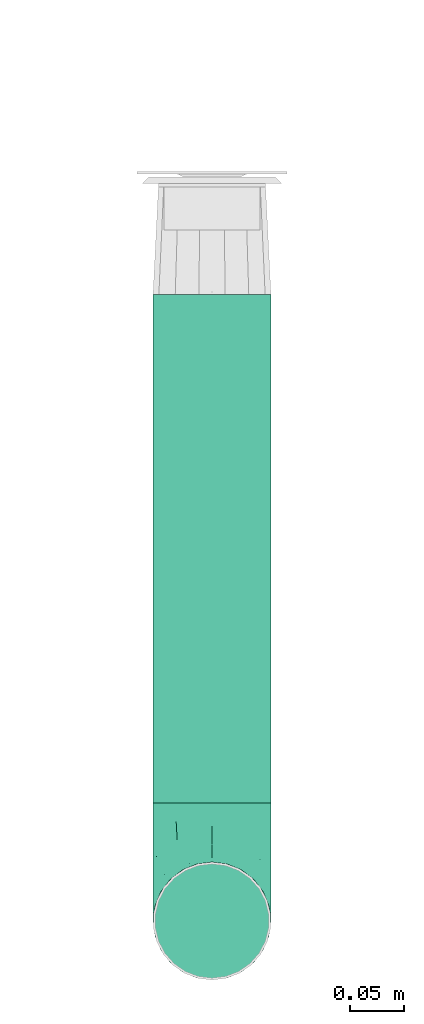
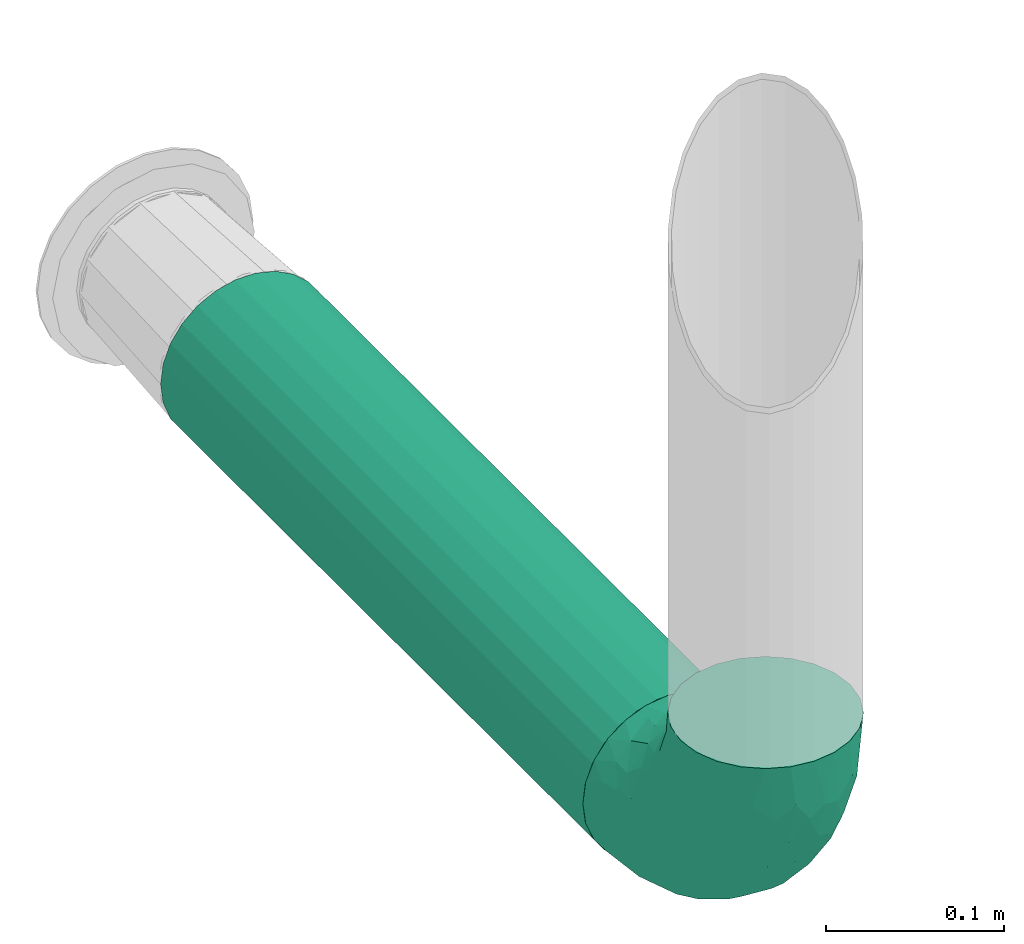
# One storey, part 13 of 115: 1 flow fitting, 1 flow segment.
"""IFC2X3 building model written with IfcOpenShell, lengths in millimetres."""

from ifc_helpers import new_model, entity, si_unit, converted_unit, derived_unit, direction, frame, origin_with_axes, origin_2d_with_axis, place, context, subcontext, project, spatial, hollow_circle, extrude, open_shell, surface_model, source, transform, mapped, material, layer, layer_set, layer_usage, type_object, element, save


model = new_model("IFC2X3")

# Units and contexts
model_context = context("Model", 3, precision=1e-05, world=origin_with_axes(), true_north=direction((0.0, 1.0)))
body_context = subcontext(model_context, "Body", "Model", "MODEL_VIEW")
ifc_project = project(units=[si_unit("AREAUNIT", "SQUARE_METRE"), si_unit("VOLUMEUNIT", "CUBIC_METRE", prefix="DECI"), si_unit("TIMEUNIT", "SECOND"), si_unit("THERMODYNAMICTEMPERATUREUNIT", "DEGREE_CELSIUS"), si_unit("PRESSUREUNIT", "PASCAL"), si_unit("MASSUNIT", "GRAM", prefix="KILO"), si_unit("LENGTHUNIT", "METRE", prefix="MILLI"), si_unit("POWERUNIT", "WATT"), si_unit("ELECTRICCURRENTUNIT", "AMPERE"), si_unit("ELECTRICVOLTAGEUNIT", "VOLT"), derived_unit("VOLUMETRICFLOWRATEUNIT", [(si_unit("VOLUMEUNIT", "CUBIC_METRE", prefix="DECI"), 1), (si_unit("TIMEUNIT", "SECOND"), -1)]), derived_unit("LINEARVELOCITYUNIT", [(si_unit("LENGTHUNIT", "METRE"), 1), (si_unit("TIMEUNIT", "SECOND"), -1)]), derived_unit("MASSDENSITYUNIT", [(si_unit("MASSUNIT", "GRAM", prefix="KILO"), 1), (si_unit("VOLUMEUNIT", "CUBIC_METRE"), -1)]), converted_unit("PLANEANGLEUNIT", "DEGREE", entity("IfcRatioMeasure", 0.01745), si_unit("PLANEANGLEUNIT", "RADIAN"), dimensions=[0, 0, 0, 0, 0, 0, 0])], contexts=[model_context])

# Site, building, storey
site_placement = place(None, origin_with_axes())
site = spatial("IfcSite", under=ifc_project, at=site_placement, CompositionType="ELEMENT")
building_placement = place(site_placement, origin_with_axes())
building = spatial("IfcBuilding", under=site, at=building_placement, Name="mc-building", CompositionType="ELEMENT")
storey_placement = place(building_placement, frame((0.0, 0.0, 2950.0), z_axis=(0.0, 0.0, 1.0), x_axis=(1.0, 0.0, 0.0)))
storey = spatial("IfcBuildingStorey", under=building, at=storey_placement, Name="2. Korrus", CompositionType="ELEMENT", Elevation=2950.0)

# Flow fitting
duct_fitting_type = type_object("IfcDuctFittingType", Name="BU", PredefinedType="BEND")
shared_shape_1 = source(origin_with_axes(), body_context, "Body", "SurfaceModel", [
    surface_model("IfcShellBasedSurfaceModel", [(-110.0, 0.0, -55.0), (-110.0, -14.23505, -53.12592), (-110.0, 14.23505, -53.12592), (-110.0, 53.12592, 14.23505), (-110.0, 27.5, -47.63139), (-110.0, 38.89087, -38.89087), (-110.0, -55.0, 0.0), (-110.0, -53.12592, 14.23505), (-110.0, -38.89087, -38.89087), (-110.0, -27.5, -47.63139), (-110.0, -53.12592, -14.23505), (-110.0, -47.63139, -27.5), (-110.0, -14.23505, 53.12592), (-110.0, 14.23505, 53.12592), (-110.0, 27.5, 47.63139), (-110.0, -47.63139, 27.5), (-110.0, -38.89087, 38.89087), (-110.0, -27.5, 47.63139), (-110.0, 0.0, 55.0), (-110.0, 55.0, 0.0), (-110.0, 53.12592, -14.23505), (-110.0, 47.63139, -27.5), (-110.0, 47.63139, 27.5), (-110.0, 38.89087, 38.89087), (-14.23505, 110.0, -53.12592), (-55.0, 110.0, 0.0), (0.0, 110.0, -55.0), (-27.5, 110.0, -47.63139), (-38.89087, 110.0, -38.89087), (-47.63139, 110.0, -27.5), (38.89087, 110.0, -38.89087), (53.12592, 110.0, 14.23505), (27.5, 110.0, -47.63139), (14.23505, 110.0, -53.12592), (47.63139, 110.0, -27.5), (53.12592, 110.0, -14.23505), (55.0, 110.0, 0.0), (-53.12592, 110.0, -14.23505), (-53.12592, 110.0, 14.23505), (-47.63139, 110.0, 27.5), (-38.89087, 110.0, 38.89087), (-27.5, 110.0, 47.63139), (0.0, 110.0, 55.0), (-14.23505, 110.0, 53.12592), (38.89087, 110.0, 38.89087), (47.63139, 110.0, 27.5), (27.5, 110.0, 47.63139), (14.23505, 110.0, 53.12592), (-64.21732, 48.68956, 43.63444), (-76.6405, 38.18013, 45.55988), (-60.44912, 32.56953, 51.94617), (-76.00813, 5.38378, 55.0), (-90.15553, 11.94394, 54.09138), (-78.5998, 26.77405, 50.81338), (-70.18771, 18.55163, 54.03432), (-75.55424, 54.2118, 32.41257), (-93.27622, 45.77614, 33.48188), (-96.12334, 22.13664, 50.81337), (-21.00813, 45.34362, 55.0), (-18.36258, 70.48427, 54.04484), (-32.04182, 59.64019, 52.24446), (-63.88653, 74.77858, 17.99134), (-74.66383, 63.08407, 19.92123), (-63.60674, 66.07878, 29.97482), (-99.597, 52.72185, 18.52927), (-93.11138, 56.59448, 10.50359), (-98.21577, 57.34403, 0.0), (-53.42855, 92.60092, 21.04759), (-88.54852, 54.8376, 21.04759), (-11.86161, 90.23965, 54.10313), (-5.38378, 76.00813, 55.0), (-57.34403, 98.21577, 0.0), (-56.64619, 93.12774, 10.22088), (-45.34362, 21.00813, 55.0), (-44.60838, 44.60838, 52.13415), (-92.68484, 35.46673, 43.63443), (-22.25266, 95.40765, 50.81337), (-35.97783, 90.61597, 43.63443), (-43.70931, 69.58671, 44.47149), (-27.23711, 77.39884, 50.81337), (-57.2828, 79.3123, 24.9774), (-58.67786, 84.31125, 16.04456), (-82.93277, 60.36161, 12.91784), (-49.88337, 54.51816, 47.224), (-74.57753, 66.83759, 9.55742), (-45.35812, 94.97281, 33.48188), (-59.18663, 88.95241, 0.0), (-51.517, 78.6292, 33.48188), (-65.14788, 80.03077, 0.0), (-56.45322, 62.06476, 39.63545), (-88.95241, 59.18663, 0.0), (-71.10913, 71.10913, 0.0), (-80.03077, 65.14788, 0.0), (-94.9309, 45.36788, -33.48188), (-93.11358, 56.60141, -10.46614), (-99.64997, 52.79499, -18.30015), (-90.20425, 36.08686, -43.63443), (-79.99933, 46.56772, -37.92748), (-76.00813, 5.38378, -55.0), (-72.75364, 19.68651, -53.60527), (-45.34362, 21.00813, -55.0), (-21.91957, 65.12078, -53.85897), (-5.38378, 76.00813, -55.0), (-21.00813, 45.34362, -55.0), (-35.41876, 92.89265, -43.63443), (-91.10309, 11.02766, -54.21832), (-45.77614, 93.27622, -33.48188), (-90.50474, 23.21022, -50.81337), (-70.92854, 33.31794, -49.51754), (-78.52933, 63.35627, -11.73997), (-24.91508, 84.05606, -50.81337), (-88.78941, 54.74452, -21.04759), (-69.59921, 57.34866, -33.48187), (-73.36422, 62.46673, -22.94182), (-63.49062, 67.59111, -28.46929), (-56.59448, 93.11138, -10.50359), (-54.8376, 88.54852, -21.04759), (-54.10679, 75.85581, -32.31867), (-57.75956, 31.09612, -52.80882), (-52.72185, 99.597, -18.52927), (-12.62913, 89.46304, -53.99097), (-34.46825, 66.46123, -50.04329), (-43.9837, 43.9837, -52.42279), (-65.78527, 72.58348, -17.68796), (-70.34468, 43.65295, -44.21951), (-57.47001, 51.99467, -44.91465), (-60.72547, 82.29174, -12.88567), (-42.34915, 74.24548, -43.63444), (-57.25194, 63.5016, -38.08211), (-80.95344, 53.56991, -29.32027), (-52.32891, 4.55257, -54.0482), (32.52942, 47.13398, -30.48571), (14.88266, 20.92917, -33.7947), (14.95561, 36.05775, -42.26543), (30.24048, 70.09027, -41.7461), (19.3559, 65.35825, -48.00507), (-70.35075, -46.44478, -19.5952), (-47.13398, -32.52942, -30.48571), (-28.49299, -30.5778, -16.4009), (-4.55257, 52.32891, -54.0482), (-22.4954, 22.4954, -53.25347), (-75.47368, -11.22546, -52.60718), (-81.32209, -51.5606, -9.98467), (-80.81763, -41.84862, -32.14655), (-70.09027, -30.24048, -41.7461), (-36.05774, -14.95561, -42.26543), (-9.15831, -10.852, -27.8997), (-65.35825, -19.3559, -48.00507), (11.22546, 75.47368, -52.60718), (3.94376, 43.9333, -50.53315), (-13.39742, 13.39743, -48.13058), (-43.9333, -3.94376, -50.53315), (49.37776, 67.29486, 0.0), (41.8609, 47.82256, -9.92641), (50.20582, 74.51695, -9.9731), (18.93131, 11.7156, -17.56239), (-27.5, -32.89419, 0.0), (-1.23348, -12.25375, -12.18106), (41.84862, 80.81763, -32.14655), (35.70604, 41.31408, -20.38235), (46.44478, 70.35075, -19.5952), (32.89419, 27.5, 0.0), (6.67262, -6.67262, 0.0), (-67.29486, -49.37776, 0.0), (-50.36265, -42.95545, -9.51562), (-5.47251, 5.47251, -39.92906), (-70.35075, -46.44478, 19.5952), (-74.51695, -50.20582, 9.9731), (-41.31407, -35.70604, 20.38235), (-47.13398, -32.52942, 30.48571), (-80.81763, -41.84862, 32.14655), (-4.55257, 52.32891, 54.0482), (11.22546, 75.47368, 52.60718), (-43.9333, -3.94376, 50.53315), (-65.35825, -19.3559, 48.00507), (-36.05774, -14.95561, 42.26543), (-70.09027, -30.24048, 41.7461), (-11.7156, -18.93131, 17.56239), (30.5778, 28.49299, 16.4009), (12.25375, 1.23348, 12.18106), (51.5606, 81.32209, 9.98467), (42.95545, 50.36265, 9.51562), (-75.47368, -11.22546, 52.60718), (-52.32891, 4.55257, 54.0482), (3.94376, 43.9333, 50.53315), (-22.4954, 22.4954, 53.25347), (-13.39742, 13.39743, 48.13058), (10.852, 9.15831, 27.8997), (-20.92916, -14.88266, 33.79469), (-47.82256, -41.8609, 9.92641), (32.52942, 47.13398, 30.48571), (46.44478, 70.35075, 19.5952), (41.84862, 80.81763, 32.14655), (30.24048, 70.09027, 41.7461), (19.3559, 65.35825, 48.00507), (14.95561, 36.05775, 42.26543), (-5.47251, 5.47251, 39.92906)], [open_shell([[[0, 1, 2]], [[2, 3, 4]], [[4, 3, 5]], [[2, 6, 7]], [[8, 6, 9]], [[1, 9, 6]], [[10, 6, 11]], [[8, 11, 6]], [[6, 2, 1]], [[12, 13, 14]], [[15, 2, 7]], [[16, 17, 2]], [[2, 17, 12]], [[12, 18, 13]], [[19, 20, 3]], [[5, 3, 21]], [[20, 21, 3]], [[22, 3, 2]], [[23, 22, 2]], [[12, 14, 2]], [[2, 14, 23]], [[15, 16, 2]], [[24, 25, 26]], [[27, 25, 24]], [[25, 28, 29]], [[28, 25, 27]], [[30, 26, 31]], [[26, 30, 32]], [[32, 33, 26]], [[34, 31, 35]], [[31, 34, 30]], [[35, 31, 36]], [[29, 37, 25]], [[38, 39, 26]], [[39, 40, 26]], [[41, 42, 40]], [[42, 26, 40]], [[42, 41, 43]], [[26, 44, 45]], [[31, 26, 45]], [[26, 46, 44]], [[47, 46, 26]], [[42, 47, 26]], [[25, 38, 26]], [[48, 49, 50]], [[18, 51, 52]], [[53, 54, 50]], [[55, 56, 49]], [[56, 22, 23]], [[13, 57, 14]], [[58, 59, 60]], [[61, 62, 63]], [[3, 64, 65]], [[53, 52, 54]], [[3, 65, 66]], [[67, 39, 38]], [[56, 68, 64]], [[65, 64, 68]], [[69, 59, 70]], [[38, 71, 72]], [[73, 58, 74]], [[75, 49, 56]], [[76, 69, 43]], [[53, 57, 52]], [[77, 78, 79]], [[41, 76, 43]], [[43, 69, 42]], [[55, 68, 56]], [[23, 14, 75]], [[76, 77, 79]], [[80, 67, 81]], [[62, 82, 68]], [[60, 78, 83]], [[62, 84, 82]], [[85, 77, 40]], [[81, 67, 72]], [[86, 72, 71]], [[87, 85, 67]], [[61, 81, 88]], [[77, 41, 40]], [[78, 77, 87]], [[23, 75, 56]], [[83, 89, 48]], [[85, 40, 39]], [[62, 68, 55]], [[89, 87, 63]], [[83, 48, 50]], [[57, 75, 14]], [[49, 75, 53]], [[67, 85, 39]], [[87, 77, 85]], [[63, 62, 55]], [[89, 55, 48]], [[80, 63, 87]], [[66, 65, 90]], [[66, 19, 3]], [[84, 91, 92]], [[92, 90, 82]], [[65, 82, 90]], [[61, 84, 62]], [[92, 82, 84]], [[68, 82, 65]], [[3, 22, 64]], [[56, 64, 22]], [[38, 25, 71]], [[81, 72, 86]], [[38, 72, 67]], [[91, 61, 88]], [[80, 81, 61]], [[63, 80, 61]], [[67, 80, 87]], [[77, 76, 41]], [[79, 59, 69]], [[79, 69, 76]], [[42, 69, 70]], [[60, 59, 79]], [[58, 70, 59]], [[78, 60, 79]], [[58, 60, 74]], [[52, 57, 13]], [[75, 57, 53]], [[18, 52, 13]], [[52, 51, 54]], [[51, 73, 54]], [[50, 73, 74]], [[73, 50, 54]], [[50, 74, 83]], [[60, 83, 74]], [[89, 83, 78]], [[87, 89, 78]], [[55, 89, 63]], [[50, 49, 53]], [[55, 49, 48]], [[81, 86, 88]], [[91, 84, 61]], [[5, 21, 93]], [[90, 94, 66]], [[20, 94, 95]], [[96, 93, 97]], [[98, 99, 100]], [[96, 4, 5]], [[101, 102, 103]], [[28, 27, 104]], [[2, 105, 0]], [[104, 106, 28]], [[99, 105, 107]], [[108, 107, 96]], [[90, 109, 94]], [[107, 2, 4]], [[20, 66, 94]], [[27, 24, 110]], [[109, 111, 94]], [[112, 113, 114]], [[37, 115, 71]], [[116, 106, 117]], [[99, 118, 100]], [[116, 115, 119]], [[37, 119, 115]], [[24, 120, 110]], [[121, 110, 101]], [[119, 106, 116]], [[101, 110, 120]], [[122, 103, 100]], [[117, 123, 116]], [[124, 125, 108]], [[115, 116, 126]], [[106, 29, 28]], [[26, 102, 120]], [[127, 104, 110]], [[97, 124, 96]], [[125, 122, 118]], [[128, 127, 125]], [[96, 5, 93]], [[115, 126, 86]], [[117, 106, 127]], [[111, 113, 129]], [[95, 93, 21]], [[97, 129, 112]], [[110, 104, 27]], [[106, 104, 127]], [[96, 107, 4]], [[99, 107, 108]], [[99, 108, 118]], [[105, 99, 98]], [[112, 114, 128]], [[121, 125, 127]], [[20, 19, 66]], [[109, 90, 92]], [[94, 111, 95]], [[91, 123, 109]], [[129, 113, 112]], [[93, 95, 111]], [[21, 20, 95]], [[71, 115, 86]], [[71, 25, 37]], [[123, 91, 88]], [[126, 116, 123]], [[123, 88, 126]], [[86, 126, 88]], [[37, 29, 119]], [[106, 119, 29]], [[129, 93, 111]], [[124, 112, 125]], [[0, 105, 98]], [[107, 105, 2]], [[125, 118, 108]], [[100, 118, 122]], [[93, 129, 97]], [[113, 111, 109]], [[109, 123, 113]], [[114, 123, 117]], [[123, 114, 113]], [[128, 114, 117]], [[127, 128, 117]], [[112, 128, 125]], [[103, 122, 101]], [[110, 121, 127]], [[101, 122, 121]], [[125, 121, 122]], [[26, 120, 24]], [[101, 120, 102]], [[96, 124, 108]], [[92, 91, 109]], [[112, 124, 97]], [[100, 130, 98]], [[131, 132, 133]], [[32, 134, 135]], [[136, 137, 138]], [[139, 140, 103]], [[98, 141, 0]], [[142, 10, 136]], [[143, 144, 137]], [[6, 10, 142]], [[137, 145, 146]], [[144, 147, 145]], [[143, 136, 11]], [[11, 136, 10]], [[8, 143, 11]], [[148, 149, 139]], [[8, 9, 144]], [[9, 1, 147]], [[130, 141, 98]], [[103, 140, 100]], [[148, 135, 149]], [[150, 151, 140]], [[152, 153, 154]], [[130, 140, 151]], [[148, 26, 33]], [[147, 1, 141]], [[155, 146, 132]], [[156, 138, 157]], [[134, 30, 158]], [[150, 140, 149]], [[158, 30, 34]], [[30, 134, 32]], [[153, 159, 160]], [[131, 160, 159]], [[144, 145, 137]], [[36, 152, 154]], [[146, 138, 137]], [[155, 161, 162]], [[158, 160, 131]], [[133, 149, 135]], [[156, 163, 164]], [[163, 142, 164]], [[139, 103, 102]], [[153, 152, 161]], [[34, 35, 160]], [[162, 157, 155]], [[132, 165, 133]], [[157, 146, 155]], [[140, 130, 100]], [[141, 130, 151]], [[141, 151, 147]], [[141, 1, 0]], [[102, 26, 148]], [[140, 139, 149]], [[102, 148, 139]], [[135, 33, 32]], [[151, 150, 145]], [[9, 147, 144]], [[151, 145, 147]], [[145, 165, 146]], [[135, 148, 33]], [[133, 135, 134]], [[131, 133, 134]], [[133, 165, 150]], [[133, 150, 149]], [[145, 150, 165]], [[132, 131, 159]], [[146, 165, 132]], [[160, 158, 34]], [[134, 158, 131]], [[144, 143, 8]], [[136, 143, 137]], [[155, 153, 161]], [[154, 153, 160]], [[153, 155, 159]], [[132, 159, 155]], [[160, 35, 154]], [[36, 154, 35]], [[164, 136, 138]], [[6, 142, 163]], [[136, 164, 142]], [[156, 164, 138]], [[156, 157, 162]], [[146, 157, 138]], [[15, 7, 166]], [[6, 163, 167]], [[168, 169, 166]], [[166, 169, 170]], [[171, 172, 70]], [[173, 174, 175]], [[17, 176, 174]], [[177, 156, 162]], [[176, 16, 170]], [[170, 16, 15]], [[161, 178, 179]], [[152, 180, 181]], [[182, 173, 183]], [[18, 12, 182]], [[184, 185, 186]], [[183, 185, 73]], [[183, 73, 51]], [[177, 187, 188]], [[189, 168, 166]], [[187, 178, 190]], [[16, 176, 17]], [[161, 152, 181]], [[45, 191, 31]], [[45, 44, 192]], [[192, 191, 45]], [[180, 36, 31]], [[193, 194, 195]], [[46, 47, 194]], [[193, 195, 190]], [[193, 44, 46]], [[172, 42, 70]], [[185, 58, 73]], [[189, 163, 156]], [[163, 189, 167]], [[70, 58, 171]], [[184, 171, 185]], [[169, 188, 175]], [[180, 31, 191]], [[192, 193, 190]], [[191, 190, 178]], [[182, 174, 173]], [[194, 47, 172]], [[190, 195, 187]], [[186, 185, 173]], [[162, 179, 177]], [[188, 196, 175]], [[179, 187, 177]], [[185, 171, 58]], [[172, 171, 184]], [[172, 184, 194]], [[172, 47, 42]], [[51, 18, 182]], [[185, 183, 173]], [[51, 182, 183]], [[174, 12, 17]], [[184, 186, 195]], [[46, 194, 193]], [[184, 195, 194]], [[195, 196, 187]], [[174, 182, 12]], [[175, 174, 176]], [[169, 175, 176]], [[175, 196, 186]], [[175, 186, 173]], [[195, 186, 196]], [[188, 169, 168]], [[187, 196, 188]], [[166, 170, 15]], [[176, 170, 169]], [[193, 192, 44]], [[191, 192, 190]], [[177, 189, 156]], [[167, 189, 166]], [[189, 177, 168]], [[188, 168, 177]], [[166, 7, 167]], [[6, 167, 7]], [[181, 191, 178]], [[36, 180, 152]], [[191, 181, 180]], [[161, 181, 178]], [[161, 179, 162]], [[187, 179, 178]]])]),
])
flow_fitting_placement = place(storey_placement, frame((7914.47808, -687.64676, 2300.0), z_axis=(-1.0, 0.0, 0.0), x_axis=(0.0, -1.0, 0.0)))
element("IfcFlowFitting", 1, at=flow_fitting_placement, inside=storey, type_object=duct_fitting_type, Name="BU", context=body_context, shape_type="MappedRepresentation", body=[
    mapped(shared_shape_1, transform((0.0, 0.0, 0.0), scale=1.0)),
])

# Flow segment
ifc_material = material(Name="FZ1")
ifc_layer = layer(ifc_material, 0.0)
ifc_layer_set = layer_set([ifc_layer], Name="FZ1")
ifc_layer_usage = layer_usage(ifc_layer_set, "AXIS1", "POSITIVE", 0.0)
duct_segment_type = type_object("IfcDuctSegmentType", PredefinedType="RIGIDSEGMENT")
shared_shape_2 = source(origin_with_axes(), body_context, "Body", "SweptSolid", [
    extrude(hollow_circle(Radius=55.0, WallThickness=2.0, at=origin_2d_with_axis()), frame((0.0, 0.0, 0.0), z_axis=(1.0, 0.0, 0.0), x_axis=(0.0, 1.0, 0.0)), (0.0, 0.0, 1.0), 474.5),
])
flow_segment_placement = place(storey_placement, frame((7914.47808, -103.1, 2300.0), z_axis=(0.0, 0.0, 1.0), x_axis=(0.0, -1.0, 0.0)))
element("IfcFlowSegment", 2, at=flow_segment_placement, inside=storey, type_object=duct_segment_type, material=ifc_layer_usage, context=body_context, shape_type="MappedRepresentation", body=[
    mapped(shared_shape_2, transform((0.0, 0.0, 0.0), scale=1.0)),
])

save(model, "model.ifc")
